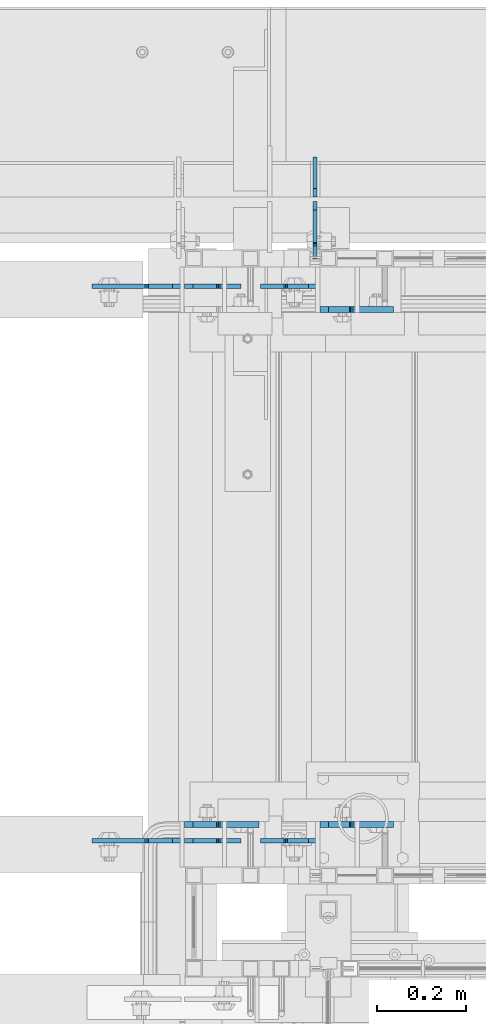
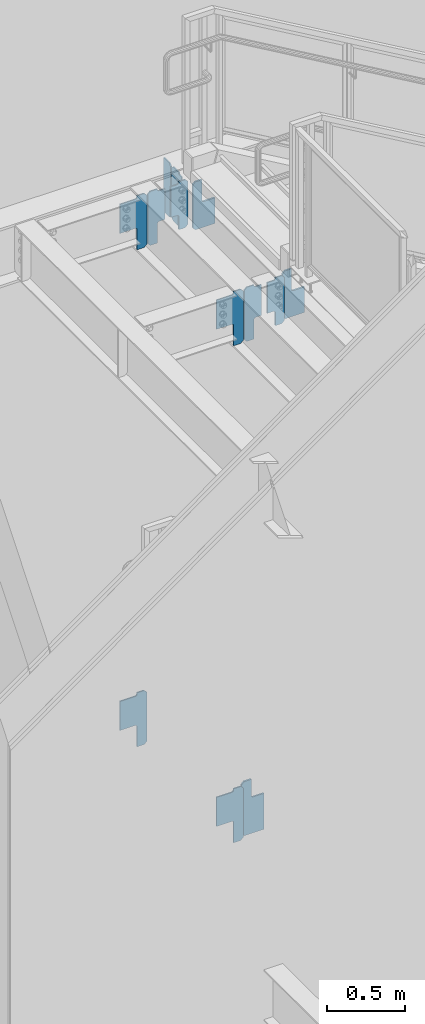
# One storey, part 1112 of 1179: 13 plates, 4 elements without a shape of their own.
"""IFC2X3 building model written with IfcOpenShell, lengths in millimetres."""

from ifc_helpers import new_model, si_unit, frame, origin_with_axes, place, context, subcontext, project, spatial, faceted_brep, material, type_object, element, aggregate, save


model = new_model("IFC2X3")

# Units and contexts
model_context = context("Model", 3, precision=1e-05, world=origin_with_axes())
body_context = subcontext(model_context, "Body", "Model", "MODEL_VIEW")
ifc_project = project(units=[si_unit("LENGTHUNIT", "METRE", prefix="MILLI"), si_unit("AREAUNIT", "SQUARE_METRE"), si_unit("VOLUMEUNIT", "CUBIC_METRE"), si_unit("MASSUNIT", "GRAM", prefix="KILO"), si_unit("TIMEUNIT", "SECOND"), si_unit("PLANEANGLEUNIT", "RADIAN"), si_unit("SOLIDANGLEUNIT", "STERADIAN"), si_unit("THERMODYNAMICTEMPERATUREUNIT", "DEGREE_CELSIUS"), si_unit("LUMINOUSINTENSITYUNIT", "LUMEN")], contexts=[model_context])

# Site, building, storey
site_placement = place(None, origin_with_axes())
site = spatial("IfcSite", under=ifc_project, at=site_placement, CompositionType="ELEMENT")
building_placement = place(site_placement, origin_with_axes())
building = spatial("IfcBuilding", under=site, at=building_placement, Name="Undefined", CompositionType="ELEMENT")
storey_placement = place(building_placement, origin_with_axes())
storey = spatial("IfcBuildingStorey", under=building, at=storey_placement, Name="Undefined", CompositionType="ELEMENT", Elevation=0.0)

# Assembly, plate
assembly_1_placement = place(storey_placement, origin_with_axes())
assembly_1 = element("IfcElementAssembly", 1, at=assembly_1_placement, inside=storey, Name="BEAM", AssemblyPlace="NOTDEFINED", PredefinedType="RIGID_FRAME")
ifc_material = material(Name="STEEL/A36")
plate_type_1 = type_object("IfcPlateType", PredefinedType="NOTDEFINED")
plate_1_placement = place(assembly_1_placement, frame((19580.225, 41003.5374999803, 7623.175), z_axis=(0.0, 0.0, 1.0), x_axis=(-1.0, 0.0, 0.0)))
plate_1 = element("IfcPlate", 2, at=plate_1_placement, type_object=plate_type_1, material=ifc_material, Name="PLATE", context=body_context, shape_type="Brep", body=[
    faceted_brep([(66.6749997905281, -4.76249999999709, 0.0), (66.6749997905281, 4.76249999999709, 0.0), (66.6749997905281, 4.76249999999709, 104.775000190735), (66.6749997905281, -4.76249999999709, 104.775000190735), (67.6417297131156, 4.76249999999709, 109.635079708781), (67.6417297131156, -4.76249999999709, 109.635079708781), (70.3947436135932, 4.76249999999709, 113.755256176934), (70.3947436135932, -4.76249999999709, 113.755256176934), (74.5149200817468, 4.76249999999709, 116.508270077413), (74.5149200817468, -4.76249999999709, 116.508270077413), (79.3749995997932, 4.76249999999709, 117.475), (79.3749995997932, -4.76249999999709, 117.475), (127.000000007174, -4.76249999999709, 117.475), (127.0, 4.76249999999709, 117.475), (19.0499992370605, -4.76250000000073, 0.0), (0.0, -4.76250000000073, 19.0499992370605), (0.0, 4.76250000000073, 19.0499992370605), (19.0499992370605, 4.76250000000073, 0.0), (0.0, -4.76249999999709, 358.775000762939), (0.0, 4.76249999999709, 358.775000762939), (19.0499992370605, -4.76249999999709, 377.825), (19.0499992370605, 4.76249999999709, 377.825), (66.6749998164378, -4.76249999999709, 377.825), (66.6749998164378, 4.76249999999709, 377.825), (66.6749999434469, -4.76249999999709, 371.474999553748), (66.6749999434469, 4.76249999999709, 371.474999553748), (67.641729938794, -4.76249999999709, 366.614920114053), (67.641729938794, 4.76249999999709, 366.614920114053), (70.394743855788, -4.76249999999709, 362.494743732281), (70.394743855788, 4.76249999999709, 362.494743732281), (74.5149202922948, -4.76249999999709, 359.741729897201), (74.5149202922948, 4.76249999999709, 359.741729897201), (79.3749997512095, -4.76249999999709, 358.774999998475), (79.3749997512095, 4.76249999999709, 358.774999998475), (127.000000004868, -4.76249999999709, 358.774999992755), (127.0, 4.76249999999709, 358.774999992755)], [[[0, 1, 2, 3]], [[3, 2, 4, 5]], [[5, 4, 6, 7]], [[7, 6, 8, 9]], [[9, 8, 10, 11]], [[12, 11, 10, 13]], [[14, 15, 16, 17]], [[15, 18, 19, 16]], [[18, 20, 21, 19]], [[21, 20, 22, 23]], [[22, 24, 25, 23]], [[26, 27, 25, 24]], [[28, 29, 27, 26]], [[30, 31, 29, 28]], [[32, 33, 31, 30]], [[34, 35, 33, 32]], [[35, 34, 12, 13]], [[8, 6, 4, 2, 1, 17, 16, 19, 21, 23, 25, 27, 29, 31, 33, 35, 13, 10]], [[14, 17, 1, 0]], [[34, 32, 30, 28, 26, 24, 22, 20, 18, 15, 14, 0, 3, 5, 7, 9, 11, 12]]]),
])

assembly_2_placement = place(storey_placement, origin_with_axes())
assembly_2 = element("IfcElementAssembly", 3, at=assembly_2_placement, inside=storey, Name="BEAM", AssemblyPlace="NOTDEFINED", PredefinedType="RIGID_FRAME")
plate_2_placement = place(assembly_2_placement, frame((19282.56875, 41003.5374999803, 7573.9625), z_axis=(0.0, 0.0, 1.0), x_axis=(1.0, 0.0, 0.0)))
plate_2 = element("IfcPlate", 4, at=plate_2_placement, type_object=plate_type_1, material=ifc_material, Name="PLATE", context=body_context, shape_type="Brep", body=[
    faceted_brep([(72.2312502153181, -4.76249999999709, 425.45), (72.2312502153181, -4.76249999999709, 420.687499809265), (72.2312502153181, 4.76249999999709, 420.687499809265), (72.2312502153181, 4.76249999999709, 425.45), (73.1979801379057, -4.76249999999709, 415.82742029122), (73.1979801379057, 4.76249999999709, 415.82742029122), (75.9509940383832, -4.76249999999709, 411.707243823066), (75.9509940383832, 4.76249999999709, 411.707243823066), (80.0711705065369, -4.76249999999709, 408.954229922588), (80.0711705065369, 4.76249999999709, 408.954229922588), (84.9312500245833, -4.76249999999709, 407.9875), (84.9312500245833, 4.76249999999709, 407.9875), (126.999999992826, -4.76249999999709, 407.9875), (127.0, 4.76249999999709, 407.9875), (0.0, -4.76249999999709, 406.400000762939), (19.0499992370605, -4.76249999999709, 425.45), (19.0499992370605, 4.76249999999709, 425.45), (0.0, 4.76249999999709, 406.400000762939), (0.0, -4.76250000000073, 19.0499992370605), (0.0, 4.76250000000073, 19.0499992370605), (19.0499992370605, -4.76250000000073, 0.0), (19.0499992370605, 4.76250000000073, 0.0), (72.2312502153181, 4.76249999999709, 0.0), (72.2312502153181, -4.76249999999709, 0.0), (72.2312502153181, 4.76249999999709, 153.987500190735), (72.2312502153181, -4.76249999999709, 153.987500190735), (73.1979801379057, 4.76249999999709, 158.84757970878), (73.1979801379057, -4.76249999999709, 158.84757970878), (75.9509940383832, 4.76249999999709, 162.967756176934), (75.9509940383832, -4.76249999999709, 162.967756176934), (80.0711705065369, 4.76249999999709, 165.720770077412), (80.0711705065369, -4.76249999999709, 165.720770077412), (84.9312500245833, 4.76249999999709, 166.6875), (84.9312500245833, -4.76249999999709, 166.6875), (126.999999992826, -4.76249999999709, 166.6875), (127.0, 4.76249999999709, 166.6875)], [[[0, 1, 2, 3]], [[4, 5, 2, 1]], [[6, 7, 5, 4]], [[8, 9, 7, 6]], [[10, 11, 9, 8]], [[12, 13, 11, 10]], [[14, 15, 16, 17]], [[18, 14, 17, 19]], [[20, 18, 19, 21]], [[20, 21, 22, 23]], [[23, 22, 24, 25]], [[25, 24, 26, 27]], [[27, 26, 28, 29]], [[29, 28, 30, 31]], [[31, 30, 32, 33]], [[34, 33, 32, 35]], [[8, 6, 4, 1, 0, 15, 14, 18, 20, 23, 25, 27, 29, 31, 33, 34, 12, 10]], [[16, 15, 0, 3]], [[35, 32, 30, 28, 26, 24, 22, 21, 19, 17, 16, 3, 2, 5, 7, 9, 11, 13]], [[34, 35, 13, 12]]]),
])

# Plate
plate_3_placement = place(assembly_1_placement, frame((19580.225, 39758.9376219799, 7623.175), z_axis=(0.0, 0.0, 1.0), x_axis=(-1.0, 0.0, 0.0)))
plate_3 = element("IfcPlate", 5, at=plate_3_placement, type_object=plate_type_1, material=ifc_material, Name="PLATE", context=body_context, shape_type="Brep", body=[
    faceted_brep([(66.6749997905281, -4.76249999999709, 0.0), (66.6749997905281, 4.76249999999709, 0.0), (66.6749997905281, 4.76249999999709, 104.775000190735), (66.6749997905281, -4.76249999999709, 104.775000190735), (67.6417297131156, 4.76249999999709, 109.635079708781), (67.6417297131156, -4.76249999999709, 109.635079708781), (70.3947436135932, 4.76249999999709, 113.755256176934), (70.3947436135932, -4.76249999999709, 113.755256176934), (74.5149200817468, 4.76249999999709, 116.508270077413), (74.5149200817468, -4.76249999999709, 116.508270077413), (79.3749995997932, 4.76249999999709, 117.475), (79.3749995997932, -4.76249999999709, 117.475), (127.000000007174, -4.76249999999709, 117.475), (127.0, 4.76249999999709, 117.475), (19.0499992370605, -4.76250000000073, 0.0), (0.0, -4.76250000000073, 19.0499992370605), (0.0, 4.76250000000073, 19.0499992370605), (19.0499992370605, 4.76250000000073, 0.0), (0.0, -4.76249999999709, 358.775000762939), (0.0, 4.76249999999709, 358.775000762939), (19.0499992370605, -4.76249999999709, 377.825), (19.0499992370605, 4.76249999999709, 377.825), (66.6749998164378, -4.76249999999709, 377.825), (66.6749998164378, 4.76249999999709, 377.825), (66.6749999434469, -4.76249999999709, 371.474999553748), (66.6749999434469, 4.76249999999709, 371.474999553748), (67.641729938794, -4.76249999999709, 366.614920114053), (67.641729938794, 4.76249999999709, 366.614920114053), (70.394743855788, -4.76249999999709, 362.494743732281), (70.394743855788, 4.76249999999709, 362.494743732281), (74.5149202922948, -4.76249999999709, 359.741729897201), (74.5149202922948, 4.76249999999709, 359.741729897201), (79.3749997512095, -4.76249999999709, 358.774999998475), (79.3749997512095, 4.76249999999709, 358.774999998475), (127.000000004868, -4.76249999999709, 358.774999992755), (127.0, 4.76249999999709, 358.774999992755)], [[[0, 1, 2, 3]], [[3, 2, 4, 5]], [[5, 4, 6, 7]], [[7, 6, 8, 9]], [[9, 8, 10, 11]], [[12, 11, 10, 13]], [[14, 15, 16, 17]], [[15, 18, 19, 16]], [[18, 20, 21, 19]], [[21, 20, 22, 23]], [[22, 24, 25, 23]], [[26, 27, 25, 24]], [[28, 29, 27, 26]], [[30, 31, 29, 28]], [[32, 33, 31, 30]], [[34, 35, 33, 32]], [[35, 34, 12, 13]], [[8, 6, 4, 2, 1, 17, 16, 19, 21, 23, 25, 27, 29, 31, 33, 35, 13, 10]], [[14, 17, 1, 0]], [[34, 32, 30, 28, 26, 24, 22, 20, 18, 15, 14, 0, 3, 5, 7, 9, 11, 12]]]),
])

plate_4_placement = place(assembly_2_placement, frame((19282.56875, 39758.937500021, 7573.9625), z_axis=(0.0, 0.0, 1.0), x_axis=(1.0, 0.0, 0.0)))
plate_4 = element("IfcPlate", 6, at=plate_4_placement, type_object=plate_type_1, material=ifc_material, Name="PLATE", context=body_context, shape_type="Brep", body=[
    faceted_brep([(72.2312502153181, -4.76249999999709, 425.45), (72.2312502153181, -4.76249999999709, 420.687499809265), (72.2312502153181, 4.76249999999709, 420.687499809265), (72.2312502153181, 4.76249999999709, 425.45), (73.1979801379057, -4.76249999999709, 415.82742029122), (73.1979801379057, 4.76249999999709, 415.82742029122), (75.9509940383832, -4.76249999999709, 411.707243823066), (75.9509940383832, 4.76249999999709, 411.707243823066), (80.0711705065369, -4.76249999999709, 408.954229922588), (80.0711705065369, 4.76249999999709, 408.954229922588), (84.9312500245833, -4.76249999999709, 407.9875), (84.9312500245833, 4.76249999999709, 407.9875), (126.999999992826, -4.76249999999709, 407.9875), (127.0, 4.76249999999709, 407.9875), (0.0, -4.76249999999709, 406.400000762939), (19.0499992370605, -4.76249999999709, 425.45), (19.0499992370605, 4.76249999999709, 425.45), (0.0, 4.76249999999709, 406.400000762939), (0.0, -4.76250000000073, 19.0499992370605), (0.0, 4.76250000000073, 19.0499992370605), (19.0499992370605, -4.76250000000073, 0.0), (19.0499992370605, 4.76250000000073, 0.0), (72.2312502153181, 4.76249999999709, 0.0), (72.2312502153181, -4.76249999999709, 0.0), (72.2312502153181, 4.76249999999709, 153.987500190735), (72.2312502153181, -4.76249999999709, 153.987500190735), (73.1979801379057, 4.76249999999709, 158.84757970878), (73.1979801379057, -4.76249999999709, 158.84757970878), (75.9509940383832, 4.76249999999709, 162.967756176934), (75.9509940383832, -4.76249999999709, 162.967756176934), (80.0711705065369, 4.76249999999709, 165.720770077412), (80.0711705065369, -4.76249999999709, 165.720770077412), (84.9312500245833, 4.76249999999709, 166.6875), (84.9312500245833, -4.76249999999709, 166.6875), (126.999999992826, -4.76249999999709, 166.6875), (127.0, 4.76249999999709, 166.6875)], [[[0, 1, 2, 3]], [[4, 5, 2, 1]], [[6, 7, 5, 4]], [[8, 9, 7, 6]], [[10, 11, 9, 8]], [[12, 13, 11, 10]], [[14, 15, 16, 17]], [[18, 14, 17, 19]], [[20, 18, 19, 21]], [[20, 21, 22, 23]], [[23, 22, 24, 25]], [[25, 24, 26, 27]], [[27, 26, 28, 29]], [[29, 28, 30, 31]], [[31, 30, 32, 33]], [[34, 33, 32, 35]], [[8, 6, 4, 1, 0, 15, 14, 18, 20, 23, 25, 27, 29, 31, 33, 34, 12, 10]], [[16, 15, 0, 3]], [[35, 32, 30, 28, 26, 24, 22, 21, 19, 17, 16, 3, 2, 5, 7, 9, 11, 13]], [[34, 35, 13, 12]]]),
])

# Assembly, plates
assembly_3_placement = place(storey_placement, origin_with_axes())
assembly_3 = element("IfcElementAssembly", 7, at=assembly_3_placement, inside=storey, Name="BEAM", AssemblyPlace="NOTDEFINED", PredefinedType="RIGID_FRAME")
plate_5_placement = place(assembly_3_placement, frame((19575.4620000839, 41193.24375, 7567.6125), z_axis=(0.0, 0.0, 1.0), x_axis=(0.0, -1.0, 0.0)))
plate_5 = element("IfcPlate", 8, at=plate_5_placement, type_object=plate_type_1, material=ifc_material, Name="PLATE", context=body_context, shape_type="Brep", body=[
    faceted_brep([(91.28125, -4.76250000000073, 425.450000000001), (91.28125, -4.76250000000073, 420.687499809264), (91.28125, 4.76250000000073, 420.687499809264), (91.28125, 4.76250000000073, 425.450000000001), (92.2479799225912, -4.76250000000073, 415.827420291219), (92.2479799225912, 4.76250000000073, 415.827420291219), (95.0009938230651, -4.76250000000073, 411.707243823065), (95.0009938230651, 4.76250000000073, 411.707243823065), (99.1211702912187, -4.76250000000073, 408.954229922587), (99.1211702912187, 4.76250000000073, 408.954229922587), (103.981249809265, -4.76250000000073, 407.987499999999), (103.981249809265, 4.76250000000073, 407.987499999999), (126.999999992826, -4.76249999999709, 407.9875), (127.0, 4.76249999999709, 407.9875), (0.0, -4.76249999999709, 406.400000762939), (19.0499992370605, -4.76249999999709, 425.45), (19.0499992370605, 4.76249999999709, 425.45), (0.0, 4.76249999999709, 406.400000762939), (0.0, -4.76250000000073, 19.0499992370605), (0.0, 4.76250000000073, 19.0499992370605), (19.0499992370605, -4.76250000000073, 0.0), (19.0499992370605, 4.76250000000073, 0.0), (127.0, -4.76250000000073, 0.0), (127.0, 4.76250000000073, 0.0)], [[[0, 1, 2, 3]], [[4, 5, 2, 1]], [[6, 7, 5, 4]], [[8, 9, 7, 6]], [[10, 11, 9, 8]], [[12, 13, 11, 10]], [[14, 15, 16, 17]], [[18, 14, 17, 19]], [[20, 18, 19, 21]], [[22, 20, 21, 23]], [[8, 6, 4, 1, 0, 15, 14, 18, 20, 22, 12, 10]], [[16, 15, 0, 3]], [[23, 21, 19, 17, 16, 3, 2, 5, 7, 9, 11, 13]], [[22, 23, 13, 12]]]),
])
plate_type_2 = type_object("IfcPlateType", PredefinedType="NOTDEFINED")
plate_6_placement = place(assembly_3_placement, frame((19575.4620000839, 41204.35625, 7567.6125), z_axis=(0.0, 0.0, 1.0), x_axis=(0.0, 1.0, 0.0)))
plate_6 = element("IfcPlate", 9, at=plate_6_placement, type_object=plate_type_2, material=ifc_material, Name="PLATE", context=body_context, shape_type="Brep", body=[
    faceted_brep([(0.0, -4.76250000000073, 19.0499992370605), (0.0, -4.76249999999709, 406.400000762939), (0.0, 4.76249999999709, 406.400000762939), (0.0, 4.76250000000073, 19.0499992370605), (19.0499992370605, -4.76249999999709, 425.45), (19.0499992370605, 4.76249999999709, 425.45), (88.9000015258789, -4.76250000000073, 425.450012207031), (88.9000015258789, 4.76250000000073, 425.450012207031), (88.8999999999996, -4.76250000000005, 0.0), (88.8999999999996, 4.76250000000005, 0.0), (19.0499992370605, -4.76250000000073, 0.0), (19.0499992370605, 4.76250000000073, 0.0)], [[[0, 1, 2, 3]], [[1, 4, 5, 2]], [[4, 6, 7, 5]], [[6, 8, 9, 7]], [[8, 10, 11, 9]], [[10, 0, 3, 11]], [[5, 7, 9, 11, 3, 2]], [[10, 8, 6, 4, 1, 0]]]),
])
aggregate(assembly_3, [plate_6, plate_5])

assembly_4_placement = place(storey_placement, origin_with_axes())
assembly_4 = element("IfcElementAssembly", 10, at=assembly_4_placement, inside=storey, Name="BEAM", AssemblyPlace="NOTDEFINED", PredefinedType="RIGID_FRAME")
plate_type_3 = type_object("IfcPlateType", PredefinedType="NOTDEFINED")
plate_7_placement = place(assembly_4_placement, frame((19274.63125, 41003.5379999842, 3681.4125), z_axis=(-0.707106781186532, 0.0, 0.707106781186563), x_axis=(-0.707106781186564, 0.0, -0.707106781186531)))
plate_7 = element("IfcPlate", 11, at=plate_7_placement, type_object=plate_type_3, material=ifc_material, Name="PLATE", context=body_context, shape_type="Brep", body=[
    faceted_brep([(0.0, -4.76249999999709, 0.0), (-273.89781169269, -4.76249999999709, 273.89781169271), (-273.89781169269, 4.76249999999709, 273.89781169271), (0.0, 4.76249999999709, 0.0), (-273.897811692763, -4.76249999999709, 300.838580055854), (-273.897811692763, 4.76249999999709, 300.838580055854), (-236.292989185966, -4.76249999999709, 338.443402562652), (-236.292989185966, 4.76249999999709, 338.443402562652), (-228.435264945156, -4.76249999999709, 330.585678321844), (-228.435264945156, 4.76249999999709, 330.585678321844), (-224.315088477006, -4.76249999999709, 327.832664421361), (-224.315088477006, 4.76249999999709, 327.832664421361), (-219.455008958963, -4.76249999999709, 326.86593449877), (-219.455008958963, 4.76249999999709, 326.86593449877), (-214.594929440924, -4.76249999999709, 327.832664421348), (-214.594929440924, 4.76249999999709, 327.832664421348), (-210.474752972777, -4.76249999999709, 330.585678321821), (-210.474752972777, 4.76249999999709, 330.585678321821), (-129.652447748695, -4.76249999999709, 411.407983545898), (-129.652447748695, 4.76249999999709, 411.407983545898), (31.9921624306025, -4.76249999999709, 249.763373366595), (31.9921624306025, 4.76249999999709, 249.763373366595), (-48.8301427934839, -4.76249999999709, 168.941068142514), (-48.8301427934839, 4.76249999999709, 168.941068142514), (-51.5831566939523, -4.76249999999709, 164.82089167437), (-51.5831566939523, 4.76249999999709, 164.82089167437), (-52.5498866165326, -4.76249999999709, 159.960812156332), (-52.5498866165326, 4.76249999999709, 159.960812156332), (-51.5831566939414, -4.76249999999709, 155.10073263829), (-51.5831566939414, 4.76249999999709, 155.10073263829), (-48.8301427934603, -4.76249999999709, 150.980556170138), (-48.8301427934603, 4.76249999999709, 150.980556170138), (64.545590869946, -4.76249999999709, 37.6048225067261), (64.545590869946, 4.76249999999709, 37.6048225067261), (26.9407683631525, -4.76249999999709, -6.18456397205591e-11), (26.9407683631525, 4.76249999999709, -6.18456397205591e-11)], [[[0, 1, 2, 3]], [[1, 4, 5, 2]], [[4, 6, 7, 5]], [[6, 8, 9, 7]], [[8, 10, 11, 9]], [[10, 12, 13, 11]], [[12, 14, 15, 13]], [[14, 16, 17, 15]], [[16, 18, 19, 17]], [[18, 20, 21, 19]], [[20, 22, 23, 21]], [[22, 24, 25, 23]], [[24, 26, 27, 25]], [[26, 28, 29, 27]], [[28, 30, 31, 29]], [[30, 32, 33, 31]], [[32, 34, 35, 33]], [[34, 0, 3, 35]], [[5, 7, 9, 11, 13, 15, 17, 19, 21, 23, 25, 27, 29, 31, 33, 35, 3, 2]], [[34, 32, 30, 28, 26, 24, 22, 20, 18, 16, 14, 12, 10, 8, 6, 4, 1, 0]]]),
])
plate_8_placement = place(assembly_4_placement, frame((19274.63125, 39758.9379999371, 3681.4125), z_axis=(-0.707106781186532, 0.0, 0.707106781186563), x_axis=(-0.707106781186564, 0.0, -0.707106781186531)))
plate_8 = element("IfcPlate", 12, at=plate_8_placement, type_object=plate_type_3, material=ifc_material, Name="PLATE", context=body_context, shape_type="Brep", body=[
    faceted_brep([(0.0, -4.76249999999709, 0.0), (-273.89781169269, -4.76249999999709, 273.89781169271), (-273.89781169269, 4.76249999999709, 273.89781169271), (0.0, 4.76249999999709, 0.0), (-273.897811692763, -4.76249999999709, 300.838580055854), (-273.897811692763, 4.76249999999709, 300.838580055854), (-236.292989185966, -4.76249999999709, 338.443402562652), (-236.292989185966, 4.76249999999709, 338.443402562652), (-228.435264945156, -4.76249999999709, 330.585678321844), (-228.435264945156, 4.76249999999709, 330.585678321844), (-224.315088477006, -4.76249999999709, 327.832664421361), (-224.315088477006, 4.76249999999709, 327.832664421361), (-219.455008958963, -4.76249999999709, 326.86593449877), (-219.455008958963, 4.76249999999709, 326.86593449877), (-214.594929440924, -4.76249999999709, 327.832664421348), (-214.594929440924, 4.76249999999709, 327.832664421348), (-210.474752972777, -4.76249999999709, 330.585678321821), (-210.474752972777, 4.76249999999709, 330.585678321821), (-129.652447748695, -4.76249999999709, 411.407983545898), (-129.652447748695, 4.76249999999709, 411.407983545898), (31.9921624306025, -4.76249999999709, 249.763373366595), (31.9921624306025, 4.76249999999709, 249.763373366595), (-48.8301427934839, -4.76249999999709, 168.941068142514), (-48.8301427934839, 4.76249999999709, 168.941068142514), (-51.5831566939523, -4.76249999999709, 164.82089167437), (-51.5831566939523, 4.76249999999709, 164.82089167437), (-52.5498866165326, -4.76249999999709, 159.960812156332), (-52.5498866165326, 4.76249999999709, 159.960812156332), (-51.5831566939414, -4.76249999999709, 155.10073263829), (-51.5831566939414, 4.76249999999709, 155.10073263829), (-48.8301427934603, -4.76249999999709, 150.980556170138), (-48.8301427934603, 4.76249999999709, 150.980556170138), (64.545590869946, -4.76249999999709, 37.6048225067261), (64.545590869946, 4.76249999999709, 37.6048225067261), (26.9407683631525, -4.76249999999709, -6.18456397205591e-11), (26.9407683631525, 4.76249999999709, -6.18456397205591e-11)], [[[0, 1, 2, 3]], [[1, 4, 5, 2]], [[4, 6, 7, 5]], [[6, 8, 9, 7]], [[8, 10, 11, 9]], [[10, 12, 13, 11]], [[12, 14, 15, 13]], [[14, 16, 17, 15]], [[16, 18, 19, 17]], [[18, 20, 21, 19]], [[20, 22, 23, 21]], [[22, 24, 25, 23]], [[24, 26, 27, 25]], [[26, 28, 29, 27]], [[28, 30, 31, 29]], [[30, 32, 33, 31]], [[32, 34, 35, 33]], [[34, 0, 3, 35]], [[5, 7, 9, 11, 13, 15, 17, 19, 21, 23, 25, 27, 29, 31, 33, 35, 3, 2]], [[34, 32, 30, 28, 26, 24, 22, 20, 18, 16, 14, 12, 10, 8, 6, 4, 1, 0]]]),
])

# Plate
plate_9_placement = place(assembly_2_placement, frame((19274.63125, 41003.5379998964, 7593.0125), z_axis=(-0.707106781186532, 0.0, 0.707106781186563), x_axis=(-0.707106781186564, 0.0, -0.707106781186531)))
plate_9 = element("IfcPlate", 13, at=plate_9_placement, type_object=plate_type_3, material=ifc_material, Name="PLATE", context=body_context, shape_type="Brep", body=[
    faceted_brep([(0.0, -4.76249999999709, 0.0), (-273.89781169269, -4.76249999999709, 273.89781169271), (-273.89781169269, 4.76249999999709, 273.89781169271), (0.0, 4.76249999999709, 0.0), (-273.897811692763, -4.76249999999709, 300.838580055854), (-273.897811692763, 4.76249999999709, 300.838580055854), (-236.292989185966, -4.76249999999709, 338.443402562652), (-236.292989185966, 4.76249999999709, 338.443402562652), (-228.435264945156, -4.76249999999709, 330.585678321844), (-228.435264945156, 4.76249999999709, 330.585678321844), (-224.315088477006, -4.76249999999709, 327.832664421361), (-224.315088477006, 4.76249999999709, 327.832664421361), (-219.455008958963, -4.76249999999709, 326.86593449877), (-219.455008958963, 4.76249999999709, 326.86593449877), (-214.594929440924, -4.76249999999709, 327.832664421348), (-214.594929440924, 4.76249999999709, 327.832664421348), (-210.474752972777, -4.76249999999709, 330.585678321821), (-210.474752972777, 4.76249999999709, 330.585678321821), (-129.652447748695, -4.76249999999709, 411.407983545898), (-129.652447748695, 4.76249999999709, 411.407983545898), (31.9921624306025, -4.76249999999709, 249.763373366595), (31.9921624306025, 4.76249999999709, 249.763373366595), (-48.8301427934839, -4.76249999999709, 168.941068142514), (-48.8301427934839, 4.76249999999709, 168.941068142514), (-51.5831566939523, -4.76249999999709, 164.82089167437), (-51.5831566939523, 4.76249999999709, 164.82089167437), (-52.5498866165326, -4.76249999999709, 159.960812156332), (-52.5498866165326, 4.76249999999709, 159.960812156332), (-51.5831566939414, -4.76249999999709, 155.10073263829), (-51.5831566939414, 4.76249999999709, 155.10073263829), (-48.8301427934603, -4.76249999999709, 150.980556170138), (-48.8301427934603, 4.76249999999709, 150.980556170138), (64.545590869946, -4.76249999999709, 37.6048225067261), (64.545590869946, 4.76249999999709, 37.6048225067261), (26.9407683631525, -4.76249999999709, -6.18456397205591e-11), (26.9407683631525, 4.76249999999709, -6.18456397205591e-11)], [[[0, 1, 2, 3]], [[1, 4, 5, 2]], [[4, 6, 7, 5]], [[6, 8, 9, 7]], [[8, 10, 11, 9]], [[10, 12, 13, 11]], [[12, 14, 15, 13]], [[14, 16, 17, 15]], [[16, 18, 19, 17]], [[18, 20, 21, 19]], [[20, 22, 23, 21]], [[22, 24, 25, 23]], [[24, 26, 27, 25]], [[26, 28, 29, 27]], [[28, 30, 31, 29]], [[30, 32, 33, 31]], [[32, 34, 35, 33]], [[34, 0, 3, 35]], [[5, 7, 9, 11, 13, 15, 17, 19, 21, 23, 25, 27, 29, 31, 33, 35, 3, 2]], [[34, 32, 30, 28, 26, 24, 22, 20, 18, 16, 14, 12, 10, 8, 6, 4, 1, 0]]]),
])

plate_10_placement = place(assembly_2_placement, frame((19274.63125, 39758.9379999371, 7593.0125), z_axis=(-0.707106781186532, 0.0, 0.707106781186563), x_axis=(-0.707106781186564, 0.0, -0.707106781186531)))
plate_10 = element("IfcPlate", 14, at=plate_10_placement, type_object=plate_type_3, material=ifc_material, Name="PLATE", context=body_context, shape_type="Brep", body=[
    faceted_brep([(0.0, -4.76249999999709, 0.0), (-273.89781169269, -4.76249999999709, 273.89781169271), (-273.89781169269, 4.76249999999709, 273.89781169271), (0.0, 4.76249999999709, 0.0), (-273.897811692763, -4.76249999999709, 300.838580055854), (-273.897811692763, 4.76249999999709, 300.838580055854), (-236.292989185966, -4.76249999999709, 338.443402562652), (-236.292989185966, 4.76249999999709, 338.443402562652), (-228.435264945156, -4.76249999999709, 330.585678321844), (-228.435264945156, 4.76249999999709, 330.585678321844), (-224.315088477006, -4.76249999999709, 327.832664421361), (-224.315088477006, 4.76249999999709, 327.832664421361), (-219.455008958963, -4.76249999999709, 326.86593449877), (-219.455008958963, 4.76249999999709, 326.86593449877), (-214.594929440924, -4.76249999999709, 327.832664421348), (-214.594929440924, 4.76249999999709, 327.832664421348), (-210.474752972777, -4.76249999999709, 330.585678321821), (-210.474752972777, 4.76249999999709, 330.585678321821), (-129.652447748695, -4.76249999999709, 411.407983545898), (-129.652447748695, 4.76249999999709, 411.407983545898), (31.9921624306025, -4.76249999999709, 249.763373366595), (31.9921624306025, 4.76249999999709, 249.763373366595), (-48.8301427934839, -4.76249999999709, 168.941068142514), (-48.8301427934839, 4.76249999999709, 168.941068142514), (-51.5831566939523, -4.76249999999709, 164.82089167437), (-51.5831566939523, 4.76249999999709, 164.82089167437), (-52.5498866165326, -4.76249999999709, 159.960812156332), (-52.5498866165326, 4.76249999999709, 159.960812156332), (-51.5831566939414, -4.76249999999709, 155.10073263829), (-51.5831566939414, 4.76249999999709, 155.10073263829), (-48.8301427934603, -4.76249999999709, 150.980556170138), (-48.8301427934603, 4.76249999999709, 150.980556170138), (64.545590869946, -4.76249999999709, 37.6048225067261), (64.545590869946, 4.76249999999709, 37.6048225067261), (26.9407683631525, -4.76249999999709, -6.18456397205591e-11), (26.9407683631525, 4.76249999999709, -6.18456397205591e-11)], [[[0, 1, 2, 3]], [[1, 4, 5, 2]], [[4, 6, 7, 5]], [[6, 8, 9, 7]], [[8, 10, 11, 9]], [[10, 12, 13, 11]], [[12, 14, 15, 13]], [[14, 16, 17, 15]], [[16, 18, 19, 17]], [[18, 20, 21, 19]], [[20, 22, 23, 21]], [[22, 24, 25, 23]], [[24, 26, 27, 25]], [[26, 28, 29, 27]], [[28, 30, 31, 29]], [[30, 32, 33, 31]], [[32, 34, 35, 33]], [[34, 0, 3, 35]], [[5, 7, 9, 11, 13, 15, 17, 19, 21, 23, 25, 27, 29, 31, 33, 35, 3, 2]], [[34, 32, 30, 28, 26, 24, 22, 20, 18, 16, 14, 12, 10, 8, 6, 4, 1, 0]]]),
])

aggregate(assembly_2, [plate_9, plate_10, plate_2, plate_4])

plate_type_4 = type_object("IfcPlateType", PredefinedType="NOTDEFINED")
plate_11_placement = place(assembly_1_placement, frame((19586.575, 40951.1500001002, 7623.175), z_axis=(0.0, 0.0, 1.0), x_axis=(1.0, 0.0, 0.0)))
plate_11 = element("IfcPlate", 15, at=plate_11_placement, type_object=plate_type_4, material=ifc_material, Name="PLATE", context=body_context, shape_type="Brep", body=[
    faceted_brep([(66.6750002153203, -6.34999999999854, 377.825), (66.6750002153203, -6.34999999999854, 214.312499809263), (66.6750002153203, 6.34999999999854, 214.312499809263), (66.6750002153203, 6.34999999999854, 377.825), (67.6417301379079, -6.34999999999854, 209.452420291218), (67.6417301379079, 6.34999999999854, 209.452420291218), (70.3947440383854, -6.34999999999854, 205.332243823064), (70.3947440383854, 6.34999999999854, 205.332243823064), (74.5149205065391, -6.34999999999854, 202.579229922586), (74.5149205065391, 6.34999999999854, 202.579229922586), (79.3750000245855, -6.34999999999854, 201.612499999998), (79.3750000245855, 6.34999999999854, 201.612499999998), (165.099999999205, -6.34999999999854, 201.612499999998), (165.100000000002, 6.34999999999854, 201.612499999998), (0.0, -6.34999999999854, 358.775000762939), (19.0499992370605, -6.34999999999854, 377.825), (19.0499992370605, 6.34999999999854, 377.825), (0.0, 6.34999999999854, 358.775000762939), (0.0, -6.35000000000036, 19.0499999999993), (0.0, 6.35000000000036, 19.0499999999993), (19.0500000000002, 6.35000000000036, 0.0), (19.0500000000002, -6.35000000000036, 0.0), (165.100000000002, -6.34999999999854, 0.0), (165.100000000002, 6.34999999999854, 0.0)], [[[0, 1, 2, 3]], [[4, 5, 2, 1]], [[6, 7, 5, 4]], [[8, 9, 7, 6]], [[10, 11, 9, 8]], [[12, 13, 11, 10]], [[14, 15, 16, 17]], [[18, 14, 17, 19]], [[19, 20, 21, 18]], [[22, 21, 20, 23]], [[8, 6, 4, 1, 0, 15, 14, 18, 21, 22, 12, 10]], [[16, 15, 0, 3]], [[23, 20, 19, 17, 16, 3, 2, 5, 7, 9, 11, 13]], [[22, 23, 13, 12]]]),
])

plate_12_placement = place(assembly_1_placement, frame((19586.575, 39795.4499999334, 7623.175), z_axis=(0.0, 0.0, 1.0), x_axis=(1.0, 0.0, 0.0)))
plate_12 = element("IfcPlate", 16, at=plate_12_placement, type_object=plate_type_4, material=ifc_material, Name="PLATE", context=body_context, shape_type="Brep", body=[
    faceted_brep([(66.6750002153203, -6.34999999999854, 377.825), (66.6750002153203, -6.34999999999854, 214.312499809263), (66.6750002153203, 6.34999999999854, 214.312499809263), (66.6750002153203, 6.34999999999854, 377.825), (67.6417301379079, -6.34999999999854, 209.452420291218), (67.6417301379079, 6.34999999999854, 209.452420291218), (70.3947440383854, -6.34999999999854, 205.332243823064), (70.3947440383854, 6.34999999999854, 205.332243823064), (74.5149205065391, -6.34999999999854, 202.579229922586), (74.5149205065391, 6.34999999999854, 202.579229922586), (79.3750000245855, -6.34999999999854, 201.612499999998), (79.3750000245855, 6.34999999999854, 201.612499999998), (165.099999999205, -6.34999999999854, 201.612499999998), (165.100000000002, 6.34999999999854, 201.612499999998), (0.0, -6.34999999999854, 358.775000762939), (19.0499992370605, -6.34999999999854, 377.825), (19.0499992370605, 6.34999999999854, 377.825), (0.0, 6.34999999999854, 358.775000762939), (0.0, -6.35000000000036, 19.0499999999993), (0.0, 6.35000000000036, 19.0499999999993), (19.0500000000002, 6.35000000000036, 0.0), (19.0500000000002, -6.35000000000036, 0.0), (165.100000000002, -6.34999999999854, 0.0), (165.100000000002, 6.34999999999854, 0.0)], [[[0, 1, 2, 3]], [[4, 5, 2, 1]], [[6, 7, 5, 4]], [[8, 9, 7, 6]], [[10, 11, 9, 8]], [[12, 13, 11, 10]], [[14, 15, 16, 17]], [[18, 14, 17, 19]], [[19, 20, 21, 18]], [[22, 21, 20, 23]], [[8, 6, 4, 1, 0, 15, 14, 18, 21, 22, 12, 10]], [[16, 15, 0, 3]], [[23, 20, 19, 17, 16, 3, 2, 5, 7, 9, 11, 13]], [[22, 23, 13, 12]]]),
])

aggregate(assembly_1, [plate_1, plate_3, plate_11, plate_12])

plate_type_5 = type_object("IfcPlateType", PredefinedType="NOTDEFINED")
plate_13_placement = place(assembly_4_placement, frame((19450.05005, 39795.4500000474, 3662.3625), z_axis=(0.0, 0.0, 1.0), x_axis=(-1.0, 0.0, 0.0)))
plate_13 = element("IfcPlate", 17, at=plate_13_placement, type_object=plate_type_5, material=ifc_material, Name="PLATE", context=body_context, shape_type="Brep", body=[
    faceted_brep([(82.5500501907336, -6.34999999999854, 282.310416121593), (82.5500501907336, 6.34999999999854, 282.310416121593), (0.0, 6.34999999999854, 282.310416121593), (0.0, -6.34999999999854, 282.310416121593), (87.41012970878, -6.34999999999854, 283.277146044181), (87.41012970878, 6.34999999999854, 283.277146044181), (91.5303061769337, -6.34999999999854, 286.030159944659), (91.5303061769337, 6.34999999999854, 286.030159944659), (94.2833200774112, -6.34999999999854, 290.150336412813), (94.2833200774112, 6.34999999999854, 290.150336412813), (95.2500499999987, -6.34999999999854, 295.010415930858), (95.2500499999987, 6.34999999999854, 295.010415930858), (95.2500499999987, -6.34999999999854, 425.45), (95.2500499999987, 6.34999999999854, 425.45), (148.431300762939, -6.34999999999854, 0.0), (0.0, -6.34999999999854, 0.0), (0.0, 6.34999999999854, 0.0), (148.431300762939, 6.34999999999854, 0.0), (167.481299999999, -6.34999999999854, 19.0499992370605), (167.481299999999, 6.34999999999854, 19.0499992370605), (167.481299999999, -6.34999999999854, 406.400000762939), (167.481299999999, 6.34999999999854, 406.400000762939), (148.431300762939, -6.34999999999854, 425.45), (148.431300762939, 6.34999999999854, 425.45)], [[[0, 1, 2, 3]], [[4, 5, 1, 0]], [[6, 7, 5, 4]], [[8, 9, 7, 6]], [[10, 11, 9, 8]], [[12, 13, 11, 10]], [[14, 15, 16, 17]], [[18, 14, 17, 19]], [[20, 18, 19, 21]], [[22, 20, 21, 23]], [[8, 6, 4, 0, 3, 15, 14, 18, 20, 22, 12, 10]], [[16, 15, 3, 2]], [[23, 21, 19, 17, 16, 2, 1, 5, 7, 9, 11, 13]], [[22, 23, 13, 12]]]),
])

aggregate(assembly_4, [plate_7, plate_8, plate_13])

save(model, "model.ifc")
